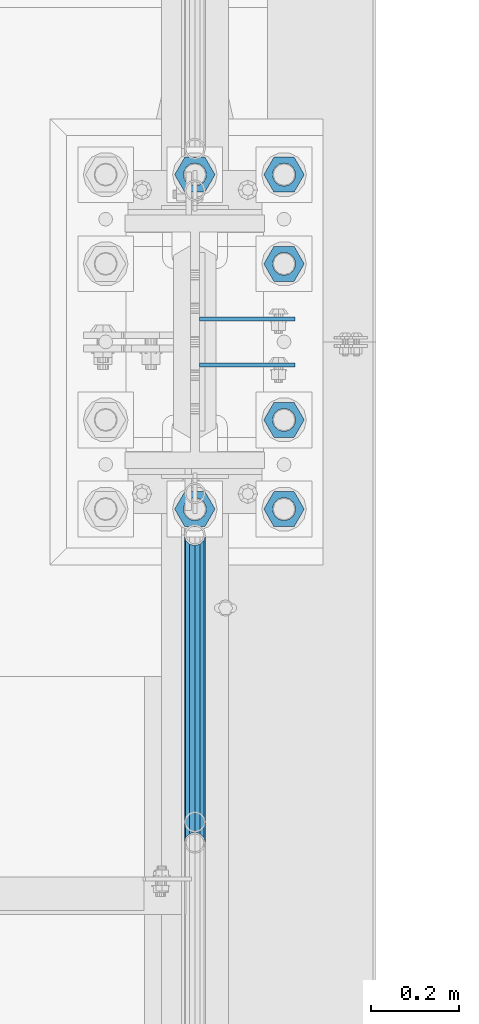
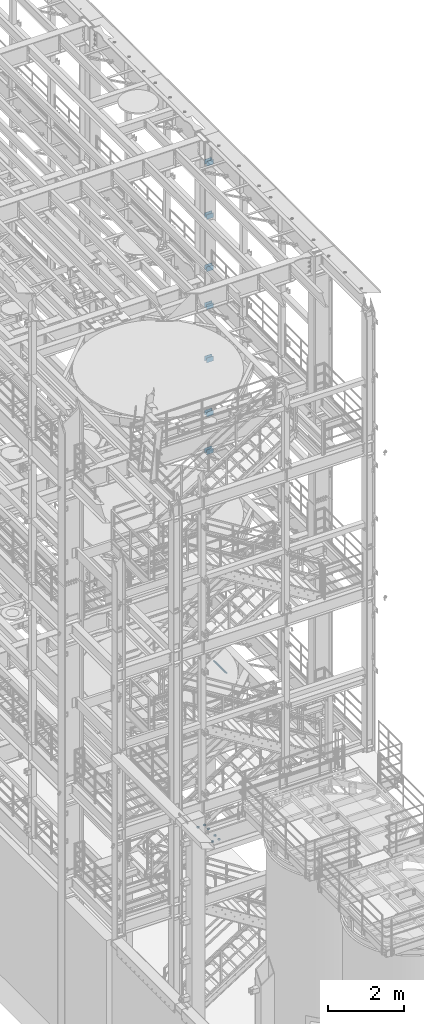
# One storey, part 1271 of 1876: 21 beams, 4 elements without a shape of their own.
"""IFC2X3 building model written with IfcOpenShell, lengths in millimetres."""

from ifc_helpers import new_model, si_unit, frame, origin_with_axes, place, context, subcontext, project, spatial, faceted_brep, material, type_object, element, aggregate, save


model = new_model("IFC2X3")

# Units and contexts
model_context = context("Model", 3, precision=1e-05, world=origin_with_axes())
body_context = subcontext(model_context, "Body", "Model", "MODEL_VIEW")
ifc_project = project(units=[si_unit("LENGTHUNIT", "METRE", prefix="MILLI"), si_unit("AREAUNIT", "SQUARE_METRE"), si_unit("VOLUMEUNIT", "CUBIC_METRE"), si_unit("MASSUNIT", "GRAM", prefix="KILO"), si_unit("TIMEUNIT", "SECOND"), si_unit("PLANEANGLEUNIT", "RADIAN"), si_unit("SOLIDANGLEUNIT", "STERADIAN"), si_unit("THERMODYNAMICTEMPERATUREUNIT", "DEGREE_CELSIUS"), si_unit("LUMINOUSINTENSITYUNIT", "LUMEN")], contexts=[model_context])

# Site, building, storey
site_placement = place(None, origin_with_axes())
site = spatial("IfcSite", under=ifc_project, at=site_placement, CompositionType="ELEMENT")
building_placement = place(site_placement, origin_with_axes())
building = spatial("IfcBuilding", under=site, at=building_placement, Name="Undefined", CompositionType="ELEMENT")
storey_placement = place(building_placement, origin_with_axes())
storey = spatial("IfcBuildingStorey", under=building, at=storey_placement, Name="Undefined", CompositionType="ELEMENT", Elevation=0.0)

# Assembly, beams
assembly_1_placement = place(storey_placement, origin_with_axes())
assembly_1 = element("IfcElementAssembly", 1, at=assembly_1_placement, inside=storey, Name="COLUMN", AssemblyPlace="NOTDEFINED", PredefinedType="RIGID_FRAME")
ifc_material_1 = material(Name="STEEL/A36")
beam_type_1 = type_object("IfcBeamType", PredefinedType="NOTDEFINED")
beam_1_placement = place(assembly_1_placement, frame((7630.31875, 1576.38750076294, 21678.9), z_axis=(0.0, 0.0, -1.0), x_axis=(1.0, 0.0, 0.0)))
beam_1 = element("IfcBeam", 2, at=beam_1_placement, type_object=beam_type_1, material=ifc_material_1, Name="PLATE", context=body_context, shape_type="Brep", body=[
    faceted_brep([(0.0, 4.76249999999982, -76.1999999999998), (3.63797880709171e-12, 4.76249999999982, 76.1999969482422), (218.28125, 4.76250000000005, 76.2000000000007), (218.28125, 4.76250000000005, -76.2000000000007), (3.63797880709171e-12, -4.76249999999982, 76.1999969482422), (218.28125, -4.76250000000005, 76.2000000000007), (0.0, -4.76249999999982, -76.1999999999998), (218.28125, -4.76250000000005, -76.2000000000007)], [[[0, 1, 2, 3]], [[1, 4, 5, 2]], [[4, 6, 7, 5]], [[6, 0, 3, 7]], [[5, 7, 3, 2]], [[6, 4, 1, 0]]]),
])
beam_2_placement = place(assembly_1_placement, frame((7630.31875, 1471.61250076294, 21678.9), z_axis=(0.0, 0.0, -1.0), x_axis=(1.0, 0.0, 0.0)))
beam_2 = element("IfcBeam", 3, at=beam_2_placement, type_object=beam_type_1, material=ifc_material_1, Name="PLATE", context=body_context, shape_type="Brep", body=[
    faceted_brep([(0.0, 4.76249999999982, -76.1999999999998), (3.63797880709171e-12, 4.76249999999982, 76.1999969482422), (218.28125, 4.76250000000005, 76.2000000000007), (218.28125, 4.76250000000005, -76.2000000000007), (3.63797880709171e-12, -4.76249999999982, 76.1999969482422), (218.28125, -4.76250000000005, 76.2000000000007), (0.0, -4.76249999999982, -76.1999999999998), (218.28125, -4.76250000000005, -76.2000000000007)], [[[0, 1, 2, 3]], [[1, 4, 5, 2]], [[4, 6, 7, 5]], [[6, 0, 3, 7]], [[5, 7, 3, 2]], [[6, 4, 1, 0]]]),
])
beam_3_placement = place(assembly_1_placement, frame((7630.31875, 1576.38750076294, 19958.05), z_axis=(0.0, 0.0, -1.0), x_axis=(1.0, 0.0, 0.0)))
beam_3 = element("IfcBeam", 4, at=beam_3_placement, type_object=beam_type_1, material=ifc_material_1, Name="PLATE", context=body_context, shape_type="Brep", body=[
    faceted_brep([(0.0, 4.76249999999982, -76.1999999999998), (3.63797880709171e-12, 4.76249999999982, 76.1999969482422), (218.28125, 4.76250000000005, 76.2000000000007), (218.28125, 4.76250000000005, -76.2000000000007), (3.63797880709171e-12, -4.76249999999982, 76.1999969482422), (218.28125, -4.76250000000005, 76.2000000000007), (0.0, -4.76249999999982, -76.1999999999998), (218.28125, -4.76250000000005, -76.2000000000007)], [[[0, 1, 2, 3]], [[1, 4, 5, 2]], [[4, 6, 7, 5]], [[6, 0, 3, 7]], [[5, 7, 3, 2]], [[6, 4, 1, 0]]]),
])
beam_4_placement = place(assembly_1_placement, frame((7630.31875, 1471.61250076294, 19958.05), z_axis=(0.0, 0.0, -1.0), x_axis=(1.0, 0.0, 0.0)))
beam_4 = element("IfcBeam", 5, at=beam_4_placement, type_object=beam_type_1, material=ifc_material_1, Name="PLATE", context=body_context, shape_type="Brep", body=[
    faceted_brep([(0.0, 4.76249999999982, -76.1999999999998), (3.63797880709171e-12, 4.76249999999982, 76.1999969482422), (218.28125, 4.76250000000005, 76.2000000000007), (218.28125, 4.76250000000005, -76.2000000000007), (3.63797880709171e-12, -4.76249999999982, 76.1999969482422), (218.28125, -4.76250000000005, 76.2000000000007), (0.0, -4.76249999999982, -76.1999999999998), (218.28125, -4.76250000000005, -76.2000000000007)], [[[0, 1, 2, 3]], [[1, 4, 5, 2]], [[4, 6, 7, 5]], [[6, 0, 3, 7]], [[5, 7, 3, 2]], [[6, 4, 1, 0]]]),
])
beam_5_placement = place(assembly_1_placement, frame((7630.31875, 1576.38750076294, 18275.3), z_axis=(0.0, 0.0, -1.0), x_axis=(1.0, 0.0, 0.0)))
beam_5 = element("IfcBeam", 6, at=beam_5_placement, type_object=beam_type_1, material=ifc_material_1, Name="PLATE", context=body_context, shape_type="Brep", body=[
    faceted_brep([(0.0, 4.76249999999982, -76.1999999999998), (3.63797880709171e-12, 4.76249999999982, 76.1999969482422), (218.28125, 4.76250000000005, 76.2000000000007), (218.28125, 4.76250000000005, -76.2000000000007), (3.63797880709171e-12, -4.76249999999982, 76.1999969482422), (218.28125, -4.76250000000005, 76.2000000000007), (0.0, -4.76249999999982, -76.1999999999998), (218.28125, -4.76250000000005, -76.2000000000007)], [[[0, 1, 2, 3]], [[1, 4, 5, 2]], [[4, 6, 7, 5]], [[6, 0, 3, 7]], [[5, 7, 3, 2]], [[6, 4, 1, 0]]]),
])
beam_6_placement = place(assembly_1_placement, frame((7630.31875, 1471.61250076294, 18275.3), z_axis=(0.0, 0.0, -1.0), x_axis=(1.0, 0.0, 0.0)))
beam_6 = element("IfcBeam", 7, at=beam_6_placement, type_object=beam_type_1, material=ifc_material_1, Name="PLATE", context=body_context, shape_type="Brep", body=[
    faceted_brep([(0.0, 4.76249999999982, -76.1999999999998), (3.63797880709171e-12, 4.76249999999982, 76.1999969482422), (218.28125, 4.76250000000005, 76.2000000000007), (218.28125, 4.76250000000005, -76.2000000000007), (3.63797880709171e-12, -4.76249999999982, 76.1999969482422), (218.28125, -4.76250000000005, 76.2000000000007), (0.0, -4.76249999999982, -76.1999999999998), (218.28125, -4.76250000000005, -76.2000000000007)], [[[0, 1, 2, 3]], [[1, 4, 5, 2]], [[4, 6, 7, 5]], [[6, 0, 3, 7]], [[5, 7, 3, 2]], [[6, 4, 1, 0]]]),
])
beam_7_placement = place(assembly_1_placement, frame((7630.31875, 1576.38750076294, 17056.1), z_axis=(0.0, 0.0, -1.0), x_axis=(1.0, 0.0, 0.0)))
beam_7 = element("IfcBeam", 8, at=beam_7_placement, type_object=beam_type_1, material=ifc_material_1, Name="PLATE", context=body_context, shape_type="Brep", body=[
    faceted_brep([(0.0, 4.76249999999982, -76.1999999999998), (3.63797880709171e-12, 4.76249999999982, 76.1999969482422), (218.28125, 4.76250000000005, 76.2000000000007), (218.28125, 4.76250000000005, -76.2000000000007), (3.63797880709171e-12, -4.76249999999982, 76.1999969482422), (218.28125, -4.76250000000005, 76.2000000000007), (0.0, -4.76249999999982, -76.1999999999998), (218.28125, -4.76250000000005, -76.2000000000007)], [[[0, 1, 2, 3]], [[1, 4, 5, 2]], [[4, 6, 7, 5]], [[6, 0, 3, 7]], [[5, 7, 3, 2]], [[6, 4, 1, 0]]]),
])
beam_8_placement = place(assembly_1_placement, frame((7630.31875, 1471.61250076294, 17056.1), z_axis=(0.0, 0.0, -1.0), x_axis=(1.0, 0.0, 0.0)))
beam_8 = element("IfcBeam", 9, at=beam_8_placement, type_object=beam_type_1, material=ifc_material_1, Name="PLATE", context=body_context, shape_type="Brep", body=[
    faceted_brep([(0.0, 4.76249999999982, -76.1999999999998), (3.63797880709171e-12, 4.76249999999982, 76.1999969482422), (218.28125, 4.76250000000005, 76.2000000000007), (218.28125, 4.76250000000005, -76.2000000000007), (3.63797880709171e-12, -4.76249999999982, 76.1999969482422), (218.28125, -4.76250000000005, 76.2000000000007), (0.0, -4.76249999999982, -76.1999999999998), (218.28125, -4.76250000000005, -76.2000000000007)], [[[0, 1, 2, 3]], [[1, 4, 5, 2]], [[4, 6, 7, 5]], [[6, 0, 3, 7]], [[5, 7, 3, 2]], [[6, 4, 1, 0]]]),
])
beam_9_placement = place(assembly_1_placement, frame((7630.31875, 1576.38750076294, 15335.25), z_axis=(0.0, 0.0, -1.0), x_axis=(1.0, 0.0, 0.0)))
beam_9 = element("IfcBeam", 10, at=beam_9_placement, type_object=beam_type_1, material=ifc_material_1, Name="PLATE", context=body_context, shape_type="Brep", body=[
    faceted_brep([(0.0, 4.76249999999982, -76.1999999999998), (3.63797880709171e-12, 4.76249999999982, 76.1999969482422), (218.28125, 4.76250000000005, 76.2000000000007), (218.28125, 4.76250000000005, -76.2000000000007), (3.63797880709171e-12, -4.76249999999982, 76.1999969482422), (218.28125, -4.76250000000005, 76.2000000000007), (0.0, -4.76249999999982, -76.1999999999998), (218.28125, -4.76250000000005, -76.2000000000007)], [[[0, 1, 2, 3]], [[1, 4, 5, 2]], [[4, 6, 7, 5]], [[6, 0, 3, 7]], [[5, 7, 3, 2]], [[6, 4, 1, 0]]]),
])
beam_10_placement = place(assembly_1_placement, frame((7630.31875, 1471.61250076294, 15335.25), z_axis=(0.0, 0.0, -1.0), x_axis=(1.0, 0.0, 0.0)))
beam_10 = element("IfcBeam", 11, at=beam_10_placement, type_object=beam_type_1, material=ifc_material_1, Name="PLATE", context=body_context, shape_type="Brep", body=[
    faceted_brep([(0.0, 4.76249999999982, -76.1999999999998), (3.63797880709171e-12, 4.76249999999982, 76.1999969482422), (218.28125, 4.76250000000005, 76.2000000000007), (218.28125, 4.76250000000005, -76.2000000000007), (3.63797880709171e-12, -4.76249999999982, 76.1999969482422), (218.28125, -4.76250000000005, 76.2000000000007), (0.0, -4.76249999999982, -76.1999999999998), (218.28125, -4.76250000000005, -76.2000000000007)], [[[0, 1, 2, 3]], [[1, 4, 5, 2]], [[4, 6, 7, 5]], [[6, 0, 3, 7]], [[5, 7, 3, 2]], [[6, 4, 1, 0]]]),
])
aggregate(assembly_1, [beam_1, beam_2, beam_3, beam_4, beam_5, beam_6, beam_7, beam_8, beam_9, beam_10])

assembly_2_placement = place(storey_placement, origin_with_axes())
assembly_2 = element("IfcElementAssembly", 12, at=assembly_2_placement, inside=storey, Name="COLUMN", AssemblyPlace="NOTDEFINED", PredefinedType="RIGID_FRAME")
beam_11_placement = place(assembly_2_placement, frame((7630.31875, 1576.38750076294, 13589.0), z_axis=(0.0, 0.0, -1.0), x_axis=(1.0, 0.0, 0.0)))
beam_11 = element("IfcBeam", 13, at=beam_11_placement, type_object=beam_type_1, material=ifc_material_1, Name="PLATE", context=body_context, shape_type="Brep", body=[
    faceted_brep([(0.0, 4.76249999999982, -76.1999999999998), (3.63797880709171e-12, 4.76249999999982, 76.1999969482422), (218.28125, 4.76250000000005, 76.2000000000007), (218.28125, 4.76250000000005, -76.2000000000007), (3.63797880709171e-12, -4.76249999999982, 76.1999969482422), (218.28125, -4.76250000000005, 76.2000000000007), (0.0, -4.76249999999982, -76.1999999999998), (218.28125, -4.76250000000005, -76.2000000000007)], [[[0, 1, 2, 3]], [[1, 4, 5, 2]], [[4, 6, 7, 5]], [[6, 0, 3, 7]], [[5, 7, 3, 2]], [[6, 4, 1, 0]]]),
])
beam_12_placement = place(assembly_2_placement, frame((7630.31875, 1471.61250076294, 13589.0), z_axis=(0.0, 0.0, -1.0), x_axis=(1.0, 0.0, 0.0)))
beam_12 = element("IfcBeam", 14, at=beam_12_placement, type_object=beam_type_1, material=ifc_material_1, Name="PLATE", context=body_context, shape_type="Brep", body=[
    faceted_brep([(0.0, 4.76249999999982, -76.1999999999998), (3.63797880709171e-12, 4.76249999999982, 76.1999969482422), (218.28125, 4.76250000000005, 76.2000000000007), (218.28125, 4.76250000000005, -76.2000000000007), (3.63797880709171e-12, -4.76249999999982, 76.1999969482422), (218.28125, -4.76250000000005, 76.2000000000007), (0.0, -4.76249999999982, -76.1999999999998), (218.28125, -4.76250000000005, -76.2000000000007)], [[[0, 1, 2, 3]], [[1, 4, 5, 2]], [[4, 6, 7, 5]], [[6, 0, 3, 7]], [[5, 7, 3, 2]], [[6, 4, 1, 0]]]),
])
beam_13_placement = place(assembly_2_placement, frame((7630.31875, 1576.38750076294, 12369.8), z_axis=(0.0, 0.0, -1.0), x_axis=(1.0, 0.0, 0.0)))
beam_13 = element("IfcBeam", 15, at=beam_13_placement, type_object=beam_type_1, material=ifc_material_1, Name="PLATE", context=body_context, shape_type="Brep", body=[
    faceted_brep([(0.0, 4.76249999999982, -76.1999999999998), (3.63797880709171e-12, 4.76249999999982, 76.1999969482422), (218.28125, 4.76250000000005, 76.2000000000007), (218.28125, 4.76250000000005, -76.2000000000007), (3.63797880709171e-12, -4.76249999999982, 76.1999969482422), (218.28125, -4.76250000000005, 76.2000000000007), (0.0, -4.76249999999982, -76.1999999999998), (218.28125, -4.76250000000005, -76.2000000000007)], [[[0, 1, 2, 3]], [[1, 4, 5, 2]], [[4, 6, 7, 5]], [[6, 0, 3, 7]], [[5, 7, 3, 2]], [[6, 4, 1, 0]]]),
])
beam_14_placement = place(assembly_2_placement, frame((7630.31875, 1471.61250076294, 12369.8), z_axis=(0.0, 0.0, -1.0), x_axis=(1.0, 0.0, 0.0)))
beam_14 = element("IfcBeam", 16, at=beam_14_placement, type_object=beam_type_1, material=ifc_material_1, Name="PLATE", context=body_context, shape_type="Brep", body=[
    faceted_brep([(0.0, 4.76249999999982, -76.1999999999998), (3.63797880709171e-12, 4.76249999999982, 76.1999969482422), (218.28125, 4.76250000000005, 76.2000000000007), (218.28125, 4.76250000000005, -76.2000000000007), (3.63797880709171e-12, -4.76249999999982, 76.1999969482422), (218.28125, -4.76250000000005, 76.2000000000007), (0.0, -4.76249999999982, -76.1999999999998), (218.28125, -4.76250000000005, -76.2000000000007)], [[[0, 1, 2, 3]], [[1, 4, 5, 2]], [[4, 6, 7, 5]], [[6, 0, 3, 7]], [[5, 7, 3, 2]], [[6, 4, 1, 0]]]),
])
aggregate(assembly_2, [beam_11, beam_12, beam_13, beam_14])

# Assembly, beam
assembly_3_placement = place(storey_placement, origin_with_axes())
assembly_3 = element("IfcElementAssembly", 17, at=assembly_3_placement, inside=storey, Name="RAIL", AssemblyPlace="NOTDEFINED", PredefinedType="RIGID_FRAME")
ifc_material_2 = material()
beam_type_2 = type_object("IfcBeamType", Name="PIPE1-1/2SCH40", PredefinedType="NOTDEFINED")
beam_15_placement = place(assembly_3_placement, frame((7620.00000000067, 1083.9096633614, 5902.3368245991), z_axis=(0.0, 7.91400000045761e-06, -0.999999999968684), x_axis=(0.0, -0.999999999968684, -7.91400000071008e-06)))
beam_15 = element("IfcBeam", 18, at=beam_15_placement, type_object=beam_type_2, material=ifc_material_2, Name="RAIL", ObjectType="PIPE1-1/2SCH40", context=body_context, shape_type="Brep", body=[
    faceted_brep([(0.0, 24.1299999999992, 0.0), (12.0648982924813, 20.8971929933186, -12.0650000000005), (12.065101708381, 20.8971929933186, 12.0650000000005), (12.065101708381, -20.8971929933186, 12.0650000000005), (12.0648982924813, -20.8971929933186, -12.0650000000005), (0.0, -24.1299999999992, 0.0), (20.897369157401, -12.0649999999996, 20.8971929933205), (20.8973267454676, -12.0649999999277, 15.8661214312533), (15.2546577467156, -17.7076214311801, 10.223500000001), (12.5151929933249, -20.4470000000001, 0.0), (15.2544853785057, -17.7076214311801, -10.2235000000001), (20.8970592426604, -12.0649999999277, -15.8661214312533), (20.8970168307269, -12.0649999999996, -20.8971929933195), (24.1298276326506, 0.0, -20.447000000001), (24.1297965849608, 0.0, -24.130000000001), (21.390472156676, -10.2235000000001, -17.7076214311819), (21.3904721567151, 10.2235000000001, -17.7076214311819), (20.8970592426604, 12.0650000000714, -15.8661214311096), (20.8970168307269, 12.0649999999996, -20.8971929933195), (15.2544853786503, 17.7076214311801, -10.2235000000001), (12.5151929933249, 20.4470000000001, 0.0), (15.2546577468602, 17.7076214311801, 10.223500000001), (20.8973267454676, 12.0650000000714, 15.8661214311096), (20.897369157401, 12.0649999999996, 20.8971929933205), (21.3907707072121, 10.2235000000001, 17.7076214311819), (24.1301723690713, 7.18500814400613e-11, 20.447000000001), (24.1302034167611, 7.18500814400613e-11, 24.1300000000019), (21.390770707173, -10.2235000000001, 17.7076214311819), (701.33983170571, 24.1300000000001, -1.45519152283669e-11), (689.27472999733, 20.8971929933186, -12.0650000000151), (680.442462548309, 12.0649999999996, -20.8971929933323), (701.33983170571, -24.1299999999283, -1.45519152283669e-11), (689.27472999733, -20.8971929933186, -12.0650000000151), (689.27493341323, -20.8971929933186, 12.0649999999878), (680.442814874983, -12.0649999999996, 20.8971929933068), (680.442462548309, -12.0649999999996, -20.8971929933323), (677.20962828895, 0.0, -24.1300000000147), (679.949060998498, 10.2235000000001, -17.7076214311946), (677.20965933664, 0.0, -20.4470000000147), (680.442504960242, 12.0650000000714, -15.8661214311223), (680.442504960242, -12.0649999999277, -15.866121431266), (679.949060998536, -10.2235000000001, -17.7076214311946), (686.085173958994, -17.7076214311801, -10.2235000000137), (688.824638712016, -20.4470000000001, -1.36424205265939e-11), (686.085346327204, -17.7076214311801, 10.2234999999873), (680.44277246305, -12.0649999999277, 15.8661214312397), (679.949359549034, -10.2235000000001, 17.7076214311674), (677.210004073059, 2.72848410531878e-12, 20.4469999999883), (677.210035120749, 2.72848410531878e-12, 24.1299999999883), (680.442814874983, 12.0649999999996, 20.8971929933068), (689.27493341323, 20.8971929933186, 12.0649999999878), (680.44277246305, 12.0650000000714, 15.866121431096), (686.085346327061, 17.7076214311801, 10.2234999999873), (688.824638711873, 20.4470000000001, -1.36424205265939e-11), (686.085173958852, 17.7076214311801, -10.2235000000137), (679.949359548996, 10.2235000000001, 17.7076214311674)], [[[0, 1, 2]], [[3, 4, 5]], [[6, 7, 8, 9, 10, 11, 12, 4, 3]], [[13, 14, 12, 11, 15]], [[16, 17, 18, 14, 13]], [[2, 1, 18, 17, 19, 20, 21, 22, 23]], [[23, 22, 24, 25, 26]], [[26, 25, 27, 7, 6]], [[1, 0, 28, 29]], [[18, 1, 29, 30]], [[31, 32, 33]], [[6, 3, 33, 34]], [[3, 5, 31, 33]], [[5, 4, 32, 31]], [[4, 12, 35, 32]], [[12, 14, 36, 35]], [[14, 18, 30, 36]], [[37, 38, 36, 30, 39]], [[40, 35, 36, 38, 41]], [[33, 32, 35, 40, 42, 43, 44, 45, 34]], [[34, 45, 46, 47, 48]], [[26, 6, 34, 48]], [[2, 23, 49, 50]], [[23, 26, 48, 49]], [[0, 2, 50, 28]], [[28, 50, 29]], [[49, 51, 52, 53, 54, 39, 30, 29, 50]], [[48, 47, 55, 51, 49]], [[25, 24, 55, 47]], [[55, 24, 22, 21, 52, 51]], [[21, 20, 53, 52]], [[20, 19, 54, 53]], [[19, 17, 16, 37, 39, 54]], [[16, 13, 38, 37]], [[13, 15, 41, 38]], [[41, 15, 11, 10, 42, 40]], [[10, 9, 43, 42]], [[9, 8, 44, 43]], [[8, 7, 27, 46, 45, 44]], [[27, 25, 47, 46]]]),
])
aggregate(assembly_3, [beam_15])

# Assembly, beams
assembly_4_placement = place(storey_placement, origin_with_axes())
assembly_4 = element("IfcElementAssembly", 19, at=assembly_4_placement, inside=storey, Name="TEMPLATE", AssemblyPlace="NOTDEFINED", PredefinedType="RIGID_FRAME")
ifc_material_3 = material(Name="STEEL/A563")
beam_type_3 = type_object("IfcBeamType", Name="2_DIA. HALF_NUT", PredefinedType="NOTDEFINED")
beam_16_placement = place(assembly_4_placement, frame((7620.0, 1904.99999847412, 33.3375), z_axis=(0.0, -1.0, 0.0), x_axis=(0.0, 0.0, -1.0)))
beam_16 = element("IfcBeam", 20, at=beam_16_placement, type_object=beam_type_3, material=ifc_material_3, Name="NUT", ObjectType="2_DIA. HALF_NUT", context=body_context, shape_type="Brep", body=[
    faceted_brep([(0.0, -46.0369987487793, 9.09494701772928e-13), (0.0, -23.0184993743896, -39.869213104248), (25.4, -23.0184993743896, -39.869213104248), (25.4, -46.0369987487793, 9.09494701772928e-13), (0.0, 23.0184993743896, -39.869213104248), (25.4, 23.0184993743896, -39.869213104248), (0.0, 46.0369987487793, -9.09494701772928e-13), (25.4, 46.0369987487793, -9.09494701772928e-13), (0.0, 23.0184993743896, 39.869213104248), (25.4, 23.0184993743896, 39.869213104248), (0.0, -23.0184993743896, 39.869213104248), (25.4, -23.0184993743896, 39.869213104248), (0.0, 0.0, 26.1940002441406), (0.0, 11.3650617044514, 23.5999013092769), (25.4, 11.3650617044514, 23.5999013092769), (25.4, 0.0, 26.1940002441406), (0.0, 20.4791109456437, 16.3316083006703), (25.4, 20.4791109456437, 16.3316083006703), (0.0, 25.5370200498346, 5.82867859874477), (25.4, 25.5370200498346, 5.82867859874477), (0.0, 25.5370200498346, -5.82867859874477), (25.4, 25.5370200498346, -5.82867859874477), (0.0, 20.4791109456437, -16.3316083006703), (25.4, 20.4791109456437, -16.3316083006703), (0.0, 11.3650617044514, -23.5999013092769), (25.4, 11.3650617044514, -23.5999013092769), (0.0, 0.0, -26.1940002441406), (25.4, 0.0, -26.1940002441406), (0.0, -11.3650617044514, -23.5999013092769), (25.4, -11.3650617044514, -23.5999013092769), (0.0, -20.4791109456437, -16.3316083006703), (25.4, -20.4791109456437, -16.3316083006703), (0.0, -25.5370200498346, -5.82867859874477), (25.4, -25.5370200498346, -5.82867859874477), (0.0, -25.5370200498346, 5.82867859874477), (25.4, -25.5370200498346, 5.82867859874477), (0.0, -20.4791109456437, 16.3316083006703), (25.4, -20.4791109456437, 16.3316083006703), (0.0, -11.3650617044514, 23.5999013092769), (25.4, -11.3650617044514, 23.5999013092769)], [[[0, 1, 2, 3]], [[1, 4, 5, 2]], [[4, 6, 7, 5]], [[6, 8, 9, 7]], [[8, 10, 11, 9]], [[10, 0, 3, 11]], [[12, 13, 14, 15]], [[13, 16, 17, 14]], [[16, 18, 19, 17]], [[18, 20, 21, 19]], [[20, 22, 23, 21]], [[22, 24, 25, 23]], [[24, 26, 27, 25]], [[26, 28, 29, 27]], [[28, 30, 31, 29]], [[30, 32, 33, 31]], [[32, 34, 35, 33]], [[34, 36, 37, 35]], [[36, 38, 39, 37]], [[38, 12, 15, 39]], [[5, 7, 9, 11, 3, 2], [17, 19, 21, 23, 25, 27, 29, 31, 33, 35, 37, 39, 15, 14]], [[10, 8, 6, 4, 1, 0], [38, 36, 34, 32, 30, 28, 26, 24, 22, 20, 18, 16, 13, 12]]]),
])
beam_17_placement = place(assembly_4_placement, frame((7823.2, 1905.00000152588, 33.3375), z_axis=(0.0, 1.0, 0.0), x_axis=(0.0, 0.0, -1.0)))
beam_17 = element("IfcBeam", 21, at=beam_17_placement, type_object=beam_type_3, material=ifc_material_3, Name="NUT", ObjectType="2_DIA. HALF_NUT", context=body_context, shape_type="Brep", body=[
    faceted_brep([(0.0, -46.0369987487793, 9.09494701772928e-13), (0.0, -23.0184993743896, -39.869213104248), (25.4, -23.0184993743896, -39.869213104248), (25.4, -46.0369987487793, 9.09494701772928e-13), (0.0, 23.0184993743896, -39.869213104248), (25.4, 23.0184993743896, -39.869213104248), (0.0, 46.0369987487793, -9.09494701772928e-13), (25.4, 46.0369987487793, -9.09494701772928e-13), (0.0, 23.0184993743896, 39.869213104248), (25.4, 23.0184993743896, 39.869213104248), (0.0, -23.0184993743896, 39.869213104248), (25.4, -23.0184993743896, 39.869213104248), (0.0, 0.0, 26.1940002441406), (0.0, 11.3650617044514, 23.5999013092769), (25.4, 11.3650617044514, 23.5999013092769), (25.4, 0.0, 26.1940002441406), (0.0, 20.4791109456437, 16.3316083006703), (25.4, 20.4791109456437, 16.3316083006703), (0.0, 25.5370200498346, 5.82867859874477), (25.4, 25.5370200498346, 5.82867859874477), (0.0, 25.5370200498346, -5.82867859874477), (25.4, 25.5370200498346, -5.82867859874477), (0.0, 20.4791109456437, -16.3316083006703), (25.4, 20.4791109456437, -16.3316083006703), (0.0, 11.3650617044514, -23.5999013092769), (25.4, 11.3650617044514, -23.5999013092769), (0.0, 0.0, -26.1940002441406), (25.4, 0.0, -26.1940002441406), (0.0, -11.3650617044514, -23.5999013092769), (25.4, -11.3650617044514, -23.5999013092769), (0.0, -20.4791109456437, -16.3316083006703), (25.4, -20.4791109456437, -16.3316083006703), (0.0, -25.5370200498346, -5.82867859874477), (25.4, -25.5370200498346, -5.82867859874477), (0.0, -25.5370200498346, 5.82867859874477), (25.4, -25.5370200498346, 5.82867859874477), (0.0, -20.4791109456437, 16.3316083006703), (25.4, -20.4791109456437, 16.3316083006703), (0.0, -11.3650617044514, 23.5999013092769), (25.4, -11.3650617044514, 23.5999013092769)], [[[0, 1, 2, 3]], [[1, 4, 5, 2]], [[4, 6, 7, 5]], [[6, 8, 9, 7]], [[8, 10, 11, 9]], [[10, 0, 3, 11]], [[12, 13, 14, 15]], [[13, 16, 17, 14]], [[16, 18, 19, 17]], [[18, 20, 21, 19]], [[20, 22, 23, 21]], [[22, 24, 25, 23]], [[24, 26, 27, 25]], [[26, 28, 29, 27]], [[28, 30, 31, 29]], [[30, 32, 33, 31]], [[32, 34, 35, 33]], [[34, 36, 37, 35]], [[36, 38, 39, 37]], [[38, 12, 15, 39]], [[5, 7, 9, 11, 3, 2], [17, 19, 21, 23, 25, 27, 29, 31, 33, 35, 37, 39, 15, 14]], [[10, 8, 6, 4, 1, 0], [38, 36, 34, 32, 30, 28, 26, 24, 22, 20, 18, 16, 13, 12]]]),
])
beam_18_placement = place(assembly_4_placement, frame((7823.2, 1701.80000152588, 33.3375), z_axis=(0.0, 1.0, 0.0), x_axis=(0.0, 0.0, -1.0)))
beam_18 = element("IfcBeam", 22, at=beam_18_placement, type_object=beam_type_3, material=ifc_material_3, Name="NUT", ObjectType="2_DIA. HALF_NUT", context=body_context, shape_type="Brep", body=[
    faceted_brep([(0.0, -46.0369987487793, 9.09494701772928e-13), (0.0, -23.0184993743896, -39.869213104248), (25.4, -23.0184993743896, -39.869213104248), (25.4, -46.0369987487793, 9.09494701772928e-13), (0.0, 23.0184993743896, -39.869213104248), (25.4, 23.0184993743896, -39.869213104248), (0.0, 46.0369987487793, -9.09494701772928e-13), (25.4, 46.0369987487793, -9.09494701772928e-13), (0.0, 23.0184993743896, 39.869213104248), (25.4, 23.0184993743896, 39.869213104248), (0.0, -23.0184993743896, 39.869213104248), (25.4, -23.0184993743896, 39.869213104248), (0.0, 0.0, 26.1940002441406), (0.0, 11.3650617044514, 23.5999013092769), (25.4, 11.3650617044514, 23.5999013092769), (25.4, 0.0, 26.1940002441406), (0.0, 20.4791109456437, 16.3316083006703), (25.4, 20.4791109456437, 16.3316083006703), (0.0, 25.5370200498346, 5.82867859874477), (25.4, 25.5370200498346, 5.82867859874477), (0.0, 25.5370200498346, -5.82867859874477), (25.4, 25.5370200498346, -5.82867859874477), (0.0, 20.4791109456437, -16.3316083006703), (25.4, 20.4791109456437, -16.3316083006703), (0.0, 11.3650617044514, -23.5999013092769), (25.4, 11.3650617044514, -23.5999013092769), (0.0, 0.0, -26.1940002441406), (25.4, 0.0, -26.1940002441406), (0.0, -11.3650617044514, -23.5999013092769), (25.4, -11.3650617044514, -23.5999013092769), (0.0, -20.4791109456437, -16.3316083006703), (25.4, -20.4791109456437, -16.3316083006703), (0.0, -25.5370200498346, -5.82867859874477), (25.4, -25.5370200498346, -5.82867859874477), (0.0, -25.5370200498346, 5.82867859874477), (25.4, -25.5370200498346, 5.82867859874477), (0.0, -20.4791109456437, 16.3316083006703), (25.4, -20.4791109456437, 16.3316083006703), (0.0, -11.3650617044514, 23.5999013092769), (25.4, -11.3650617044514, 23.5999013092769)], [[[0, 1, 2, 3]], [[1, 4, 5, 2]], [[4, 6, 7, 5]], [[6, 8, 9, 7]], [[8, 10, 11, 9]], [[10, 0, 3, 11]], [[12, 13, 14, 15]], [[13, 16, 17, 14]], [[16, 18, 19, 17]], [[18, 20, 21, 19]], [[20, 22, 23, 21]], [[22, 24, 25, 23]], [[24, 26, 27, 25]], [[26, 28, 29, 27]], [[28, 30, 31, 29]], [[30, 32, 33, 31]], [[32, 34, 35, 33]], [[34, 36, 37, 35]], [[36, 38, 39, 37]], [[38, 12, 15, 39]], [[5, 7, 9, 11, 3, 2], [17, 19, 21, 23, 25, 27, 29, 31, 33, 35, 37, 39, 15, 14]], [[10, 8, 6, 4, 1, 0], [38, 36, 34, 32, 30, 28, 26, 24, 22, 20, 18, 16, 13, 12]]]),
])
beam_19_placement = place(assembly_4_placement, frame((7823.2, 1346.20000152588, 33.3375), z_axis=(0.0, 1.0, 0.0), x_axis=(0.0, 0.0, -1.0)))
beam_19 = element("IfcBeam", 23, at=beam_19_placement, type_object=beam_type_3, material=ifc_material_3, Name="NUT", ObjectType="2_DIA. HALF_NUT", context=body_context, shape_type="Brep", body=[
    faceted_brep([(0.0, -46.0369987487793, 9.09494701772928e-13), (0.0, -23.0184993743896, -39.869213104248), (25.4, -23.0184993743896, -39.869213104248), (25.4, -46.0369987487793, 9.09494701772928e-13), (0.0, 23.0184993743896, -39.869213104248), (25.4, 23.0184993743896, -39.869213104248), (0.0, 46.0369987487793, -9.09494701772928e-13), (25.4, 46.0369987487793, -9.09494701772928e-13), (0.0, 23.0184993743896, 39.869213104248), (25.4, 23.0184993743896, 39.869213104248), (0.0, -23.0184993743896, 39.869213104248), (25.4, -23.0184993743896, 39.869213104248), (0.0, 0.0, 26.1940002441406), (0.0, 11.3650617044514, 23.5999013092769), (25.4, 11.3650617044514, 23.5999013092769), (25.4, 0.0, 26.1940002441406), (0.0, 20.4791109456437, 16.3316083006703), (25.4, 20.4791109456437, 16.3316083006703), (0.0, 25.5370200498346, 5.82867859874477), (25.4, 25.5370200498346, 5.82867859874477), (0.0, 25.5370200498346, -5.82867859874477), (25.4, 25.5370200498346, -5.82867859874477), (0.0, 20.4791109456437, -16.3316083006703), (25.4, 20.4791109456437, -16.3316083006703), (0.0, 11.3650617044514, -23.5999013092769), (25.4, 11.3650617044514, -23.5999013092769), (0.0, 0.0, -26.1940002441406), (25.4, 0.0, -26.1940002441406), (0.0, -11.3650617044514, -23.5999013092769), (25.4, -11.3650617044514, -23.5999013092769), (0.0, -20.4791109456437, -16.3316083006703), (25.4, -20.4791109456437, -16.3316083006703), (0.0, -25.5370200498346, -5.82867859874477), (25.4, -25.5370200498346, -5.82867859874477), (0.0, -25.5370200498346, 5.82867859874477), (25.4, -25.5370200498346, 5.82867859874477), (0.0, -20.4791109456437, 16.3316083006703), (25.4, -20.4791109456437, 16.3316083006703), (0.0, -11.3650617044514, 23.5999013092769), (25.4, -11.3650617044514, 23.5999013092769)], [[[0, 1, 2, 3]], [[1, 4, 5, 2]], [[4, 6, 7, 5]], [[6, 8, 9, 7]], [[8, 10, 11, 9]], [[10, 0, 3, 11]], [[12, 13, 14, 15]], [[13, 16, 17, 14]], [[16, 18, 19, 17]], [[18, 20, 21, 19]], [[20, 22, 23, 21]], [[22, 24, 25, 23]], [[24, 26, 27, 25]], [[26, 28, 29, 27]], [[28, 30, 31, 29]], [[30, 32, 33, 31]], [[32, 34, 35, 33]], [[34, 36, 37, 35]], [[36, 38, 39, 37]], [[38, 12, 15, 39]], [[5, 7, 9, 11, 3, 2], [17, 19, 21, 23, 25, 27, 29, 31, 33, 35, 37, 39, 15, 14]], [[10, 8, 6, 4, 1, 0], [38, 36, 34, 32, 30, 28, 26, 24, 22, 20, 18, 16, 13, 12]]]),
])
beam_20_placement = place(assembly_4_placement, frame((7823.2, 1143.00000152588, 33.3375), z_axis=(0.0, 1.0, 0.0), x_axis=(0.0, 0.0, -1.0)))
beam_20 = element("IfcBeam", 24, at=beam_20_placement, type_object=beam_type_3, material=ifc_material_3, Name="NUT", ObjectType="2_DIA. HALF_NUT", context=body_context, shape_type="Brep", body=[
    faceted_brep([(0.0, -46.0369987487793, 9.09494701772928e-13), (0.0, -23.0184993743896, -39.869213104248), (25.4, -23.0184993743896, -39.869213104248), (25.4, -46.0369987487793, 9.09494701772928e-13), (0.0, 23.0184993743896, -39.869213104248), (25.4, 23.0184993743896, -39.869213104248), (0.0, 46.0369987487793, -9.09494701772928e-13), (25.4, 46.0369987487793, -9.09494701772928e-13), (0.0, 23.0184993743896, 39.869213104248), (25.4, 23.0184993743896, 39.869213104248), (0.0, -23.0184993743896, 39.869213104248), (25.4, -23.0184993743896, 39.869213104248), (0.0, 0.0, 26.1940002441406), (0.0, 11.3650617044514, 23.5999013092769), (25.4, 11.3650617044514, 23.5999013092769), (25.4, 0.0, 26.1940002441406), (0.0, 20.4791109456437, 16.3316083006703), (25.4, 20.4791109456437, 16.3316083006703), (0.0, 25.5370200498346, 5.82867859874477), (25.4, 25.5370200498346, 5.82867859874477), (0.0, 25.5370200498346, -5.82867859874477), (25.4, 25.5370200498346, -5.82867859874477), (0.0, 20.4791109456437, -16.3316083006703), (25.4, 20.4791109456437, -16.3316083006703), (0.0, 11.3650617044514, -23.5999013092769), (25.4, 11.3650617044514, -23.5999013092769), (0.0, 0.0, -26.1940002441406), (25.4, 0.0, -26.1940002441406), (0.0, -11.3650617044514, -23.5999013092769), (25.4, -11.3650617044514, -23.5999013092769), (0.0, -20.4791109456437, -16.3316083006703), (25.4, -20.4791109456437, -16.3316083006703), (0.0, -25.5370200498346, -5.82867859874477), (25.4, -25.5370200498346, -5.82867859874477), (0.0, -25.5370200498346, 5.82867859874477), (25.4, -25.5370200498346, 5.82867859874477), (0.0, -20.4791109456437, 16.3316083006703), (25.4, -20.4791109456437, 16.3316083006703), (0.0, -11.3650617044514, 23.5999013092769), (25.4, -11.3650617044514, 23.5999013092769)], [[[0, 1, 2, 3]], [[1, 4, 5, 2]], [[4, 6, 7, 5]], [[6, 8, 9, 7]], [[8, 10, 11, 9]], [[10, 0, 3, 11]], [[12, 13, 14, 15]], [[13, 16, 17, 14]], [[16, 18, 19, 17]], [[18, 20, 21, 19]], [[20, 22, 23, 21]], [[22, 24, 25, 23]], [[24, 26, 27, 25]], [[26, 28, 29, 27]], [[28, 30, 31, 29]], [[30, 32, 33, 31]], [[32, 34, 35, 33]], [[34, 36, 37, 35]], [[36, 38, 39, 37]], [[38, 12, 15, 39]], [[5, 7, 9, 11, 3, 2], [17, 19, 21, 23, 25, 27, 29, 31, 33, 35, 37, 39, 15, 14]], [[10, 8, 6, 4, 1, 0], [38, 36, 34, 32, 30, 28, 26, 24, 22, 20, 18, 16, 13, 12]]]),
])
beam_21_placement = place(assembly_4_placement, frame((7620.0, 1142.99999847412, 33.3375), z_axis=(0.0, -1.0, 0.0), x_axis=(0.0, 0.0, -1.0)))
beam_21 = element("IfcBeam", 25, at=beam_21_placement, type_object=beam_type_3, material=ifc_material_3, Name="NUT", ObjectType="2_DIA. HALF_NUT", context=body_context, shape_type="Brep", body=[
    faceted_brep([(0.0, -46.0369987487793, 9.09494701772928e-13), (0.0, -23.0184993743896, -39.869213104248), (25.4, -23.0184993743896, -39.869213104248), (25.4, -46.0369987487793, 9.09494701772928e-13), (0.0, 23.0184993743896, -39.869213104248), (25.4, 23.0184993743896, -39.869213104248), (0.0, 46.0369987487793, -9.09494701772928e-13), (25.4, 46.0369987487793, -9.09494701772928e-13), (0.0, 23.0184993743896, 39.869213104248), (25.4, 23.0184993743896, 39.869213104248), (0.0, -23.0184993743896, 39.869213104248), (25.4, -23.0184993743896, 39.869213104248), (0.0, 0.0, 26.1940002441406), (0.0, 11.3650617044514, 23.5999013092769), (25.4, 11.3650617044514, 23.5999013092769), (25.4, 0.0, 26.1940002441406), (0.0, 20.4791109456437, 16.3316083006703), (25.4, 20.4791109456437, 16.3316083006703), (0.0, 25.5370200498346, 5.82867859874477), (25.4, 25.5370200498346, 5.82867859874477), (0.0, 25.5370200498346, -5.82867859874477), (25.4, 25.5370200498346, -5.82867859874477), (0.0, 20.4791109456437, -16.3316083006703), (25.4, 20.4791109456437, -16.3316083006703), (0.0, 11.3650617044514, -23.5999013092769), (25.4, 11.3650617044514, -23.5999013092769), (0.0, 0.0, -26.1940002441406), (25.4, 0.0, -26.1940002441406), (0.0, -11.3650617044514, -23.5999013092769), (25.4, -11.3650617044514, -23.5999013092769), (0.0, -20.4791109456437, -16.3316083006703), (25.4, -20.4791109456437, -16.3316083006703), (0.0, -25.5370200498346, -5.82867859874477), (25.4, -25.5370200498346, -5.82867859874477), (0.0, -25.5370200498346, 5.82867859874477), (25.4, -25.5370200498346, 5.82867859874477), (0.0, -20.4791109456437, 16.3316083006703), (25.4, -20.4791109456437, 16.3316083006703), (0.0, -11.3650617044514, 23.5999013092769), (25.4, -11.3650617044514, 23.5999013092769)], [[[0, 1, 2, 3]], [[1, 4, 5, 2]], [[4, 6, 7, 5]], [[6, 8, 9, 7]], [[8, 10, 11, 9]], [[10, 0, 3, 11]], [[12, 13, 14, 15]], [[13, 16, 17, 14]], [[16, 18, 19, 17]], [[18, 20, 21, 19]], [[20, 22, 23, 21]], [[22, 24, 25, 23]], [[24, 26, 27, 25]], [[26, 28, 29, 27]], [[28, 30, 31, 29]], [[30, 32, 33, 31]], [[32, 34, 35, 33]], [[34, 36, 37, 35]], [[36, 38, 39, 37]], [[38, 12, 15, 39]], [[5, 7, 9, 11, 3, 2], [17, 19, 21, 23, 25, 27, 29, 31, 33, 35, 37, 39, 15, 14]], [[10, 8, 6, 4, 1, 0], [38, 36, 34, 32, 30, 28, 26, 24, 22, 20, 18, 16, 13, 12]]]),
])
aggregate(assembly_4, [beam_16, beam_17, beam_18, beam_19, beam_20, beam_21])

save(model, "model.ifc")
